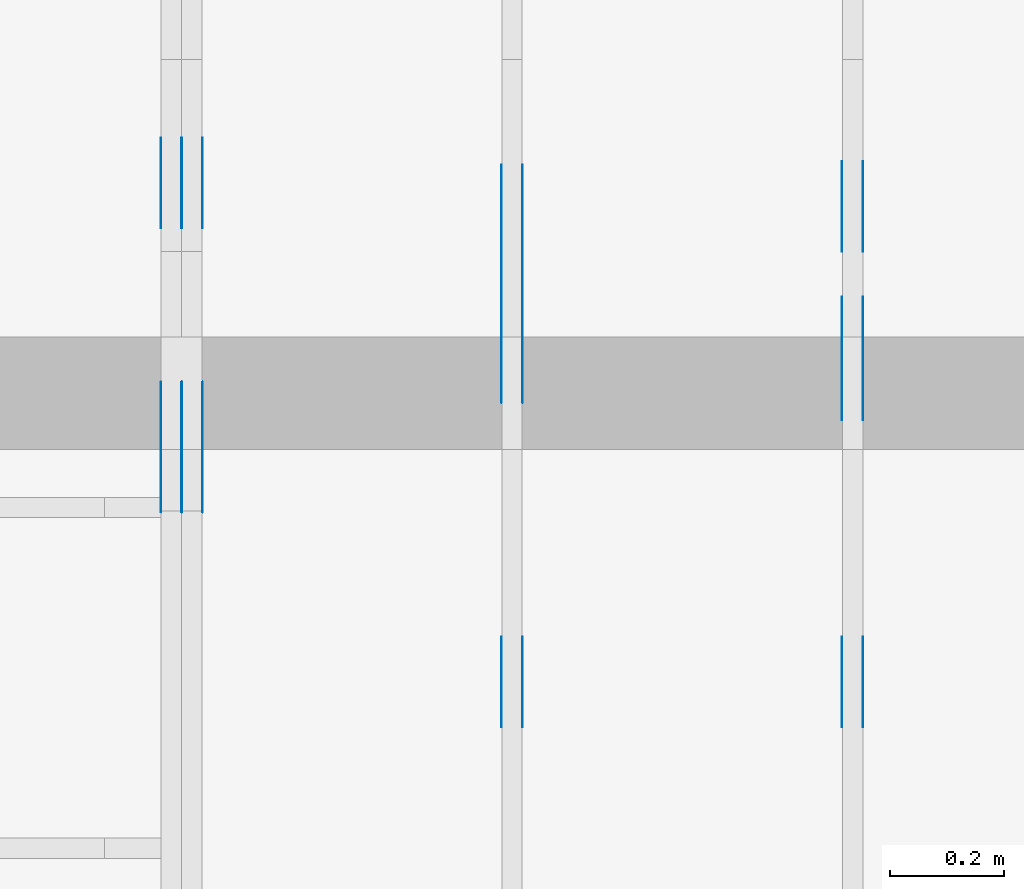
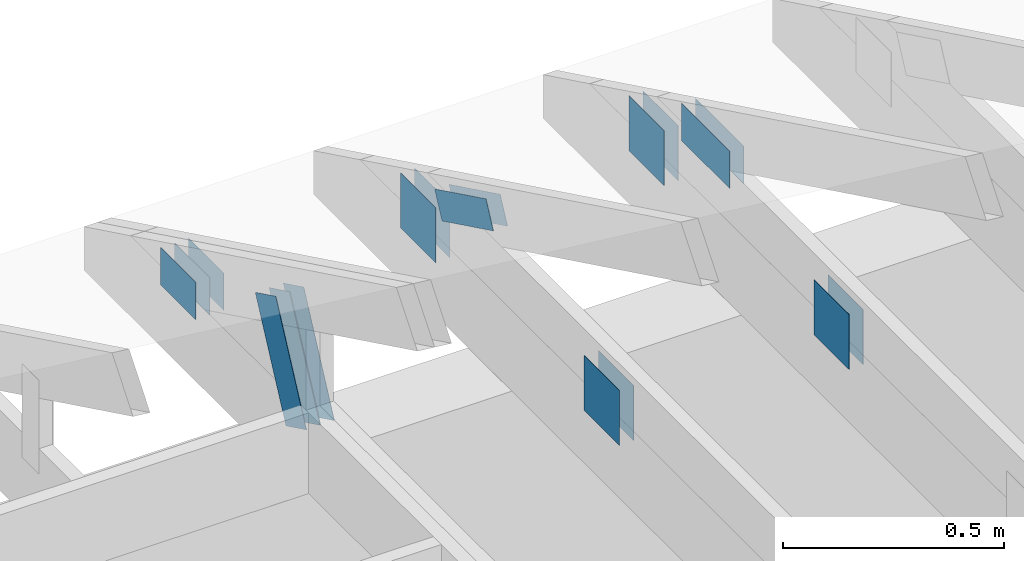
# One storey, part 91 of 159: 20 plates, 3 elements without a shape of their own.
"""IFC2X3 building model written with IfcOpenShell, lengths in millimetres."""

from ifc_helpers import new_model, si_unit, frame, origin, origin_with_axes, origin_2d, place, context, project, spatial, faceted_brep, element, aggregate, save


model = new_model("IFC2X3")

# Units and contexts
model_context = context("Model", 3, precision=1e-05, world=origin())
plan_context = context("Plan", 2, precision=1e-05, world=origin_2d())
ifc_project = project(units=[si_unit("LENGTHUNIT", "METRE", prefix="MILLI"), si_unit("AREAUNIT", "SQUARE_METRE"), si_unit("VOLUMEUNIT", "CUBIC_METRE"), si_unit("SOLIDANGLEUNIT", "STERADIAN"), si_unit("PLANEANGLEUNIT", "RADIAN"), si_unit("MASSUNIT", "GRAM"), si_unit("TIMEUNIT", "SECOND"), si_unit("THERMODYNAMICTEMPERATUREUNIT", "DEGREE_CELSIUS"), si_unit("LUMINOUSINTENSITYUNIT", "LUMEN")], contexts=[model_context, plan_context])

# Site, building, storey
site_placement = place(None, origin_with_axes())
site = spatial("IfcSite", under=ifc_project, at=site_placement, CompositionType="ELEMENT")
building_placement = place(site_placement, origin_with_axes())
building = spatial("IfcBuilding", under=site, at=building_placement, Name="Plan 1", CompositionType="ELEMENT")
storey_placement = place(building_placement, origin_with_axes())
storey = spatial("IfcBuildingStorey", under=building, at=storey_placement, Name="Etasje 1", CompositionType="ELEMENT", Elevation=0.0)

# Assembly, plates
assembly_1_placement = place(storey_placement, frame((3075.02226140475, 9699.999999999993, 1.1021457184401395e-15), z_axis=(-1.0, 1.836909530733566e-16, 6.123031769111886e-17), x_axis=(-1.836909530733566e-16, -1.0, 0.0)))
assembly_1 = element("IfcElementAssembly", 1, at=assembly_1_placement, inside=storey, Name="V3 (4)", AssemblyPlace="FACTORY", PredefinedType="TRUSS")
plate_1_placement = place(assembly_1_placement, frame((628.6262642368674, 319.5, 0.0), z_axis=(0.0, 0.0, 1.0), x_axis=(1.0, 0.0, 0.0)))
plate_1 = element("IfcPlate", 2, at=plate_1_placement, Name="GNT100S 103x218", context=model_context, shape_type="Brep", body=[
    faceted_brep([(218.00001750141382, 103.0, 1.0), (1.7501413822174072e-05, 103.0, 1.0), (1.7501413822174072e-05, 0.0, 1.0), (218.00001750141382, 0.0, 1.0), (1.7501413822174072e-05, 103.0, 2.1432342567509146e-21), (218.00001750141382, 103.0, 2.669642065656208e-14), (218.00001750141382, 0.0, 2.669642065656208e-14), (1.7501413822174072e-05, 0.0, 2.1432342567509146e-21), (218.0, 9.262934928637445e-13, 2.4519452801791947e-30), (218.0, 9.263547231814356e-13, 1.0), (1.1247455413666031e-32, 9.663993509514274e-13, 1.0), (0.0, 9.663381206337363e-13, 0.0), (218.0, 103.00000000000097, 0.0), (218.0, 103.00000000000097, 1.0), (218.0, 9.663381206337363e-13, 1.0), (218.0, 9.663381206337363e-13, 0.0), (0.0, 103.00000000000097, 0.0), (-3.7491518045553436e-33, 103.00000000000097, 1.0), (218.0, 103.00000000000095, 1.0), (218.0, 103.00000000000095, -7.888609052210118e-31), (1.1833838024688483e-28, 9.663381206337363e-13, -7.245896617569183e-45), (6.12303176912372e-17, 9.663381206337363e-13, 1.0), (1.2674675762061723e-14, 103.00000000000097, 1.0), (1.2613445444370604e-14, 103.00000000000097, -7.7232527173840805e-31)], [[[0, 1, 2, 3]], [[4, 5, 6, 7]], [[8, 9, 10, 11]], [[12, 13, 14, 15]], [[16, 17, 18, 19]], [[20, 21, 22, 23]]]),
])
plate_2_placement = place(assembly_1_placement, frame((628.6262642368674, 319.5, -37.0), z_axis=(0.0, 0.0, 1.0), x_axis=(1.0, 0.0, 0.0)))
plate_2 = element("IfcPlate", 3, at=plate_2_placement, Name="GNT100S 103x218", context=model_context, shape_type="Brep", body=[
    faceted_brep([(218.00001750141382, 103.0, 1.0), (1.7501413822174072e-05, 103.0, 1.0), (1.7501413822174072e-05, 0.0, 1.0), (218.00001750141382, 0.0, 1.0), (1.7501413822174072e-05, 103.0, 2.1432342567509146e-21), (218.00001750141382, 103.0, 2.669642065656208e-14), (218.00001750141382, 0.0, 2.669642065656208e-14), (1.7501413822174072e-05, 0.0, 2.1432342567509146e-21), (218.0, 9.262934928637445e-13, 2.4519452801791947e-30), (218.0, 9.263547231814356e-13, 1.0), (1.1247455413666031e-32, 9.663993509514274e-13, 1.0), (0.0, 9.663381206337363e-13, 0.0), (218.0, 103.00000000000097, 0.0), (218.0, 103.00000000000097, 1.0), (218.0, 9.663381206337363e-13, 1.0), (218.0, 9.663381206337363e-13, 0.0), (0.0, 103.00000000000097, 0.0), (-3.7491518045553436e-33, 103.00000000000097, 1.0), (218.0, 103.00000000000095, 1.0), (218.0, 103.00000000000095, -7.888609052210118e-31), (1.1833838024688483e-28, 9.663381206337363e-13, -7.245896617569183e-45), (6.12303176912372e-17, 9.663381206337363e-13, 1.0), (1.2674675762061723e-14, 103.00000000000097, 1.0), (1.2613445444370604e-14, 103.00000000000097, -7.7232527173840805e-31)], [[[0, 1, 2, 3]], [[4, 5, 6, 7]], [[8, 9, 10, 11]], [[12, 13, 14, 15]], [[16, 17, 18, 19]], [[20, 21, 22, 23]]]),
])
plate_3_placement = place(assembly_1_placement, frame((1227.851282296476, 147.0, 0.0), z_axis=(0.0, 0.0, 1.0), x_axis=(1.0, 0.0, 0.0)))
plate_3 = element("IfcPlate", 4, at=plate_3_placement, Name="GNT100S 152x159", context=model_context, shape_type="Brep", body=[
    faceted_brep([(159.00003606289897, 152.0, 1.0), (3.6062898971067625e-05, 152.0, 1.0), (3.6062898971067625e-05, 0.0, 1.0), (159.00003606289897, 0.0, 1.0), (3.6062898971067625e-05, 152.0, 4.4162855217223885e-21), (159.00003606289897, 152.0, 1.947124544206132e-14), (159.00003606289897, 0.0, 1.947124544206132e-14), (3.6062898971067625e-05, 0.0, 4.4162855217223885e-21), (159.0, 8.447997618295233e-14, 1.788345410772899e-30), (159.0, 8.454120650064345e-14, 1.0), (1.1247455413666031e-32, 1.1374806803930715e-13, 1.0), (0.0, 1.1368683772161603e-13, 0.0), (159.0, 152.0000000000001, 0.0), (159.0, 152.0000000000001, 1.0), (159.0, 1.1368683772161603e-13, 1.0), (159.0, 1.1368683772161603e-13, 0.0), (4.861730685829017e-63, 152.0000000000001, 0.0), (-3.7491518045553436e-33, 152.0000000000001, 1.0), (159.0, 152.0000000000001, 1.0), (159.0, 152.0000000000001, 0.0), (1.392216238198645e-29, 1.1368683772161603e-13, -8.524584255963745e-46), (6.123031769113279e-17, 1.1368683772161603e-13, 1.0), (1.8675246895791266e-14, 152.0000000000001, 1.0), (1.8614016578100147e-14, 152.0000000000001, -1.1397421485848253e-30)], [[[0, 1, 2, 3]], [[4, 5, 6, 7]], [[8, 9, 10, 11]], [[12, 13, 14, 15]], [[16, 17, 18, 19]], [[20, 21, 22, 23]]]),
])
plate_4_placement = place(assembly_1_placement, frame((1227.851282296476, 147.0, -37.0), z_axis=(0.0, 0.0, 1.0), x_axis=(1.0, 0.0, 0.0)))
plate_4 = element("IfcPlate", 5, at=plate_4_placement, Name="GNT100S 152x159", context=model_context, shape_type="Brep", body=[
    faceted_brep([(159.00003606289897, 152.0, 1.0), (3.6062898971067625e-05, 152.0, 1.0), (3.6062898971067625e-05, 0.0, 1.0), (159.00003606289897, 0.0, 1.0), (3.6062898971067625e-05, 152.0, 4.4162855217223885e-21), (159.00003606289897, 152.0, 1.947124544206132e-14), (159.00003606289897, 0.0, 1.947124544206132e-14), (3.6062898971067625e-05, 0.0, 4.4162855217223885e-21), (159.0, 8.447997618295233e-14, 1.788345410772899e-30), (159.0, 8.454120650064345e-14, 1.0), (1.1247455413666031e-32, 1.1374806803930715e-13, 1.0), (0.0, 1.1368683772161603e-13, 0.0), (159.0, 152.0000000000001, 0.0), (159.0, 152.0000000000001, 1.0), (159.0, 1.1368683772161603e-13, 1.0), (159.0, 1.1368683772161603e-13, 0.0), (4.861730685829017e-63, 152.0000000000001, 0.0), (-3.7491518045553436e-33, 152.0000000000001, 1.0), (159.0, 152.0000000000001, 1.0), (159.0, 152.0000000000001, 0.0), (1.392216238198645e-29, 1.1368683772161603e-13, -8.524584255963745e-46), (6.123031769113279e-17, 1.1368683772161603e-13, 1.0), (1.8675246895791266e-14, 152.0000000000001, 1.0), (1.8614016578100147e-14, 152.0000000000001, -1.1397421485848253e-30)], [[[0, 1, 2, 3]], [[4, 5, 6, 7]], [[8, 9, 10, 11]], [[12, 13, 14, 15]], [[16, 17, 18, 19]], [[20, 21, 22, 23]]]),
])
plate_5_placement = place(assembly_1_placement, frame((390.2917064386552, 147.0, 0.0), z_axis=(0.0, 0.0, 1.0), x_axis=(1.0, 0.0, 0.0)))
plate_5 = element("IfcPlate", 6, at=plate_5_placement, Name="GNT100S 152x159", context=model_context, shape_type="Brep", body=[
    faceted_brep([(158.99998057306357, 152.0, 1.0), (1.109064169213525e-05, 152.0, 1.0), (1.109064169213525e-05, 0.0, 1.0), (158.99998057306357, 0.0, 1.0), (1.109064169213525e-05, 152.0, 1.3581670284156189e-21), (158.99998057306357, 152.0, 1.947123864674082e-14), (158.99998057306357, 0.0, 1.947123864674082e-14), (1.109064169213525e-05, 0.0, 1.3581670284156189e-21), (159.0, 1.9816681390456836e-13, 1.788345410772899e-30), (159.0, 1.9822804422225948e-13, 1.0), (1.1247455413666031e-32, 2.274349057609232e-13, 1.0), (0.0, 2.2737367544323206e-13, 0.0), (159.0, 152.00000000000023, 0.0), (159.0, 152.00000000000023, 1.0), (159.0, 2.2737367544323206e-13, 1.0), (159.0, 2.2737367544323206e-13, 0.0), (0.0, 152.00000000000023, 0.0), (-3.7491518045553436e-33, 152.00000000000023, 1.0), (159.0, 152.00000000000023, 1.0), (159.0, 152.00000000000023, 0.0), (2.78443247639729e-29, 2.2737367544323206e-13, -1.704916851192749e-45), (6.123031769114671e-17, 2.2737367544323206e-13, 1.0), (1.8675246895791282e-14, 152.00000000000023, 1.0), (1.8614016578100163e-14, 152.00000000000023, -1.1397421485848262e-30)], [[[0, 1, 2, 3]], [[4, 5, 6, 7]], [[8, 9, 10, 11]], [[12, 13, 14, 15]], [[16, 17, 18, 19]], [[20, 21, 22, 23]]]),
])
plate_6_placement = place(assembly_1_placement, frame((390.2917064386552, 147.0, -37.0), z_axis=(0.0, 0.0, 1.0), x_axis=(1.0, 0.0, 0.0)))
plate_6 = element("IfcPlate", 7, at=plate_6_placement, Name="GNT100S 152x159", context=model_context, shape_type="Brep", body=[
    faceted_brep([(158.99998057306357, 152.0, 1.0), (1.109064169213525e-05, 152.0, 1.0), (1.109064169213525e-05, 0.0, 1.0), (158.99998057306357, 0.0, 1.0), (1.109064169213525e-05, 152.0, 1.3581670284156189e-21), (158.99998057306357, 152.0, 1.947123864674082e-14), (158.99998057306357, 0.0, 1.947123864674082e-14), (1.109064169213525e-05, 0.0, 1.3581670284156189e-21), (159.0, 1.9816681390456836e-13, 1.788345410772899e-30), (159.0, 1.9822804422225948e-13, 1.0), (1.1247455413666031e-32, 2.274349057609232e-13, 1.0), (0.0, 2.2737367544323206e-13, 0.0), (159.0, 152.00000000000023, 0.0), (159.0, 152.00000000000023, 1.0), (159.0, 2.2737367544323206e-13, 1.0), (159.0, 2.2737367544323206e-13, 0.0), (0.0, 152.00000000000023, 0.0), (-3.7491518045553436e-33, 152.00000000000023, 1.0), (159.0, 152.00000000000023, 1.0), (159.0, 152.00000000000023, 0.0), (2.78443247639729e-29, 2.2737367544323206e-13, -1.704916851192749e-45), (6.123031769114671e-17, 2.2737367544323206e-13, 1.0), (1.8675246895791282e-14, 152.00000000000023, 1.0), (1.8614016578100163e-14, 152.00000000000023, -1.1397421485848262e-30)], [[[0, 1, 2, 3]], [[4, 5, 6, 7]], [[8, 9, 10, 11]], [[12, 13, 14, 15]], [[16, 17, 18, 19]], [[20, 21, 22, 23]]]),
])
aggregate(assembly_1, [plate_1, plate_2, plate_3, plate_4, plate_5, plate_6])

assembly_2_placement = place(storey_placement, frame((2475.02226140475, 9699.999999999993, 1.1021457184401395e-15), z_axis=(-1.0, 1.836909530733566e-16, 6.123031769111886e-17), x_axis=(-1.836909530733566e-16, -1.0, 0.0)))
assembly_2 = element("IfcElementAssembly", 8, at=assembly_2_placement, inside=storey, Name="V2 (3)", AssemblyPlace="FACTORY", PredefinedType="TRUSS")
plate_7_placement = place(assembly_2_placement, frame((584.1466632894787, 280.29593737468866, 0.0), z_axis=(0.0, 0.0, 1.0), x_axis=(0.898794046299167, 0.4383711467890774, 0.0)))
plate_7 = element("IfcPlate", 9, at=plate_7_placement, Name="GNT100S 76x258", context=model_context, shape_type="Brep", body=[
    faceted_brep([(257.9999812347945, 76.00002691228983, 1.0), (0.0, 76.00002691228983, 1.0), (1.3453948326969112e-05, 1.8024312566922163e-05, 1.0), (257.99999468874285, 1.8024312566922163e-05, 1.0), (0.0, 76.00002691228983, 0.0), (257.9999812347945, 76.00002691228983, 3.159484163061835e-14), (257.99999468874285, 0.0, 3.159484327819741e-14), (1.3453948326969112e-05, 0.0, 1.6475790605204317e-21), (258.0000074628399, 8.521038589962382e-06, 2.9018435981122237e-30), (258.0000074628399, 8.521038590023613e-06, 1.0), (7.462839903382701e-06, 8.521038637415878e-06, 1.0), (7.462839903382701e-06, 8.521038637354648e-06, 9.4039548065783e-38), (258.0000074628399, 76.00000852103864, 0.0), (258.0000074628399, 76.00000852103864, 1.0), (258.0000074628399, 8.52103863735465e-06, 1.0), (258.0000074628399, 8.52103863735465e-06, 0.0), (7.462839903382702e-06, 76.00000852103861, 0.0), (7.462839903382702e-06, 76.00000852103861, 1.0), (258.0000074628399, 76.00000852103865, 1.0), (258.0000074628399, 76.00000852103865, 7.888609052210118e-31), (7.462839903382702e-06, 8.52103863735465e-06, -9.4039548065783e-38), (7.462839903443932e-06, 8.52103863735465e-06, 1.0), (7.46283991275094e-06, 76.00000852103861, 1.0), (7.46283991268971e-06, 76.00000852103861, -5.69871103679771e-31)], [[[0, 1, 2, 3]], [[4, 5, 6, 7]], [[8, 9, 10, 11]], [[12, 13, 14, 15]], [[16, 17, 18, 19]], [[20, 21, 22, 23]]]),
])
plate_8_placement = place(assembly_2_placement, frame((584.1466632894787, 280.29593737468866, -37.00000000000001), z_axis=(0.0, 0.0, 1.0), x_axis=(0.898794046299167, 0.4383711467890774, 0.0)))
plate_8 = element("IfcPlate", 10, at=plate_8_placement, Name="GNT100S 76x258", context=model_context, shape_type="Brep", body=[
    faceted_brep([(257.9999812347945, 76.00002691228983, 1.0), (0.0, 76.00002691228983, 1.0), (1.3453948326969112e-05, 1.8024312566922163e-05, 1.0), (257.99999468874285, 1.8024312566922163e-05, 1.0), (0.0, 76.00002691228983, 0.0), (257.9999812347945, 76.00002691228983, 3.159484163061835e-14), (257.99999468874285, 0.0, 3.159484327819741e-14), (1.3453948326969112e-05, 0.0, 1.6475790605204317e-21), (258.0000074628399, 8.521038589962382e-06, 2.9018435981122237e-30), (258.0000074628399, 8.521038590023613e-06, 1.0), (7.462839903382701e-06, 8.521038637415878e-06, 1.0), (7.462839903382701e-06, 8.521038637354648e-06, 9.4039548065783e-38), (258.0000074628399, 76.00000852103864, 0.0), (258.0000074628399, 76.00000852103864, 1.0), (258.0000074628399, 8.52103863735465e-06, 1.0), (258.0000074628399, 8.52103863735465e-06, 0.0), (7.462839903382702e-06, 76.00000852103861, 0.0), (7.462839903382702e-06, 76.00000852103861, 1.0), (258.0000074628399, 76.00000852103865, 1.0), (258.0000074628399, 76.00000852103865, 7.888609052210118e-31), (7.462839903382702e-06, 8.52103863735465e-06, -9.4039548065783e-38), (7.462839903443932e-06, 8.52103863735465e-06, 1.0), (7.46283991275094e-06, 76.00000852103861, 1.0), (7.46283991268971e-06, 76.00000852103861, -5.69871103679771e-31)], [[[0, 1, 2, 3]], [[4, 5, 6, 7]], [[8, 9, 10, 11]], [[12, 13, 14, 15]], [[16, 17, 18, 19]], [[20, 21, 22, 23]]]),
])
plate_9_placement = place(assembly_2_placement, frame((1227.851282296476, 147.0, 0.0), z_axis=(0.0, 0.0, 1.0), x_axis=(1.0, 0.0, 0.0)))
plate_9 = element("IfcPlate", 11, at=plate_9_placement, Name="GNT100S 152x159", context=model_context, shape_type="Brep", body=[
    faceted_brep([(159.00003606289897, 152.0, 1.0), (3.6062898971067625e-05, 152.0, 1.0), (3.6062898971067625e-05, 0.0, 1.0), (159.00003606289897, 0.0, 1.0), (3.6062898971067625e-05, 152.0, 4.4162855217223885e-21), (159.00003606289897, 152.0, 1.947124544206132e-14), (159.00003606289897, 0.0, 1.947124544206132e-14), (3.6062898971067625e-05, 0.0, 4.4162855217223885e-21), (159.0, 8.447997618295233e-14, 1.788345410772899e-30), (159.0, 8.454120650064345e-14, 1.0), (1.1247455413666031e-32, 1.1374806803930715e-13, 1.0), (0.0, 1.1368683772161603e-13, 0.0), (159.0, 152.0000000000001, 0.0), (159.0, 152.0000000000001, 1.0), (159.0, 1.1368683772161603e-13, 1.0), (159.0, 1.1368683772161603e-13, 0.0), (4.861730685829017e-63, 152.0000000000001, 0.0), (-3.7491518045553436e-33, 152.0000000000001, 1.0), (159.0, 152.0000000000001, 1.0), (159.0, 152.0000000000001, 0.0), (1.392216238198645e-29, 1.1368683772161603e-13, -8.524584255963745e-46), (6.123031769113279e-17, 1.1368683772161603e-13, 1.0), (1.8675246895791266e-14, 152.0000000000001, 1.0), (1.8614016578100147e-14, 152.0000000000001, -1.1397421485848253e-30)], [[[0, 1, 2, 3]], [[4, 5, 6, 7]], [[8, 9, 10, 11]], [[12, 13, 14, 15]], [[16, 17, 18, 19]], [[20, 21, 22, 23]]]),
])
plate_10_placement = place(assembly_2_placement, frame((1227.851282296476, 147.0, -37.0), z_axis=(0.0, 0.0, 1.0), x_axis=(1.0, 0.0, 0.0)))
plate_10 = element("IfcPlate", 12, at=plate_10_placement, Name="GNT100S 152x159", context=model_context, shape_type="Brep", body=[
    faceted_brep([(159.00003606289897, 152.0, 1.0), (3.6062898971067625e-05, 152.0, 1.0), (3.6062898971067625e-05, 0.0, 1.0), (159.00003606289897, 0.0, 1.0), (3.6062898971067625e-05, 152.0, 4.4162855217223885e-21), (159.00003606289897, 152.0, 1.947124544206132e-14), (159.00003606289897, 0.0, 1.947124544206132e-14), (3.6062898971067625e-05, 0.0, 4.4162855217223885e-21), (159.0, 8.447997618295233e-14, 1.788345410772899e-30), (159.0, 8.454120650064345e-14, 1.0), (1.1247455413666031e-32, 1.1374806803930715e-13, 1.0), (0.0, 1.1368683772161603e-13, 0.0), (159.0, 152.0000000000001, 0.0), (159.0, 152.0000000000001, 1.0), (159.0, 1.1368683772161603e-13, 1.0), (159.0, 1.1368683772161603e-13, 0.0), (4.861730685829017e-63, 152.0000000000001, 0.0), (-3.7491518045553436e-33, 152.0000000000001, 1.0), (159.0, 152.0000000000001, 1.0), (159.0, 152.0000000000001, 0.0), (1.392216238198645e-29, 1.1368683772161603e-13, -8.524584255963745e-46), (6.123031769113279e-17, 1.1368683772161603e-13, 1.0), (1.8675246895791266e-14, 152.0000000000001, 1.0), (1.8614016578100147e-14, 152.0000000000001, -1.1397421485848253e-30)], [[[0, 1, 2, 3]], [[4, 5, 6, 7]], [[8, 9, 10, 11]], [[12, 13, 14, 15]], [[16, 17, 18, 19]], [[20, 21, 22, 23]]]),
])
plate_11_placement = place(assembly_2_placement, frame((396.2348521906083, 147.0, 0.0), z_axis=(0.0, 0.0, 1.0), x_axis=(1.0, 0.0, 0.0)))
plate_11 = element("IfcPlate", 13, at=plate_11_placement, Name="GNT100S 152x159", context=model_context, shape_type="Brep", body=[
    faceted_brep([(159.0000110906417, 152.0, 1.0), (1.109064169213525e-05, 152.0, 1.0), (1.109064169213525e-05, 0.0, 1.0), (159.0000110906417, 0.0, 1.0), (1.109064169213525e-05, 152.0, 1.3581670284156189e-21), (159.0000110906417, 152.0, 1.9471242383942826e-14), (159.0000110906417, 0.0, 1.9471242383942826e-14), (1.109064169213525e-05, 0.0, 1.3581670284156189e-21), (159.0, 1.9816681390456836e-13, 1.788345410772899e-30), (159.0, 1.9822804422225948e-13, 1.0), (1.1247455413666031e-32, 2.274349057609232e-13, 1.0), (0.0, 2.2737367544323206e-13, 0.0), (159.0, 152.00000000000023, 0.0), (159.0, 152.00000000000023, 1.0), (159.0, 2.2737367544323206e-13, 1.0), (159.0, 2.2737367544323206e-13, 0.0), (0.0, 152.00000000000023, 0.0), (-3.7491518045553436e-33, 152.00000000000023, 1.0), (159.0, 152.00000000000023, 1.0), (159.0, 152.00000000000023, 0.0), (2.78443247639729e-29, 2.2737367544323206e-13, -1.704916851192749e-45), (6.123031769114671e-17, 2.2737367544323206e-13, 1.0), (1.8675246895791282e-14, 152.00000000000023, 1.0), (1.8614016578100163e-14, 152.00000000000023, -1.1397421485848262e-30)], [[[0, 1, 2, 3]], [[4, 5, 6, 7]], [[8, 9, 10, 11]], [[12, 13, 14, 15]], [[16, 17, 18, 19]], [[20, 21, 22, 23]]]),
])
plate_12_placement = place(assembly_2_placement, frame((396.2348521906083, 147.0, -37.0), z_axis=(0.0, 0.0, 1.0), x_axis=(1.0, 0.0, 0.0)))
plate_12 = element("IfcPlate", 14, at=plate_12_placement, Name="GNT100S 152x159", context=model_context, shape_type="Brep", body=[
    faceted_brep([(159.0000110906417, 152.0, 1.0), (1.109064169213525e-05, 152.0, 1.0), (1.109064169213525e-05, 0.0, 1.0), (159.0000110906417, 0.0, 1.0), (1.109064169213525e-05, 152.0, 1.3581670284156189e-21), (159.0000110906417, 152.0, 1.9471242383942826e-14), (159.0000110906417, 0.0, 1.9471242383942826e-14), (1.109064169213525e-05, 0.0, 1.3581670284156189e-21), (159.0, 1.9816681390456836e-13, 1.788345410772899e-30), (159.0, 1.9822804422225948e-13, 1.0), (1.1247455413666031e-32, 2.274349057609232e-13, 1.0), (0.0, 2.2737367544323206e-13, 0.0), (159.0, 152.00000000000023, 0.0), (159.0, 152.00000000000023, 1.0), (159.0, 2.2737367544323206e-13, 1.0), (159.0, 2.2737367544323206e-13, 0.0), (0.0, 152.00000000000023, 0.0), (-3.7491518045553436e-33, 152.00000000000023, 1.0), (159.0, 152.00000000000023, 1.0), (159.0, 152.00000000000023, 0.0), (2.78443247639729e-29, 2.2737367544323206e-13, -1.704916851192749e-45), (6.123031769114671e-17, 2.2737367544323206e-13, 1.0), (1.8675246895791282e-14, 152.00000000000023, 1.0), (1.8614016578100163e-14, 152.00000000000023, -1.1397421485848262e-30)], [[[0, 1, 2, 3]], [[4, 5, 6, 7]], [[8, 9, 10, 11]], [[12, 13, 14, 15]], [[16, 17, 18, 19]], [[20, 21, 22, 23]]]),
])
aggregate(assembly_2, [plate_7, plate_8, plate_9, plate_10, plate_11, plate_12])

assembly_3_placement = place(storey_placement, frame((1875.0222614047502, 9699.999999999993, 0.0), z_axis=(-1.0, 1.836909530733566e-16, 6.123031769111886e-17), x_axis=(-1.836909530733566e-16, -1.0, 0.0)))
assembly_3 = element("IfcElementAssembly", 15, at=assembly_3_placement, inside=storey, Name="V1 (2)", AssemblyPlace="FACTORY", PredefinedType="TRUSS")
plate_13_placement = place(assembly_3_placement, frame((348.93719482421875, 171.5, 0.0), z_axis=(0.0, 0.0, 1.0), x_axis=(1.0, 0.0, 0.0)))
plate_13 = element("IfcPlate", 16, at=plate_13_placement, Name="GNT100S 103x159", context=model_context, shape_type="Brep", body=[
    faceted_brep([(159.0, 103.0, 1.0), (0.0, 103.0, 1.0), (0.0, 0.0, 1.0), (159.0, 0.0, 1.0), (0.0, 103.0, 0.0), (159.0, 103.0, 1.9471241025775798e-14), (159.0, 0.0, 1.9471241025775798e-14), (0.0, 0.0, 0.0), (159.00001516602936, 1.1360832223220383e-12, 1.7883455813521426e-30), (159.00001516602936, 1.1361444526397294e-12, 1.0), (1.5166029356805666e-05, 1.1653513141783931e-12, 1.0), (1.5166029356805666e-05, 1.165290083860702e-12, 1.7057924370395682e-37), (159.00001516602936, 103.00000000000114, 0.0), (159.00001516602936, 103.00000000000114, 1.0), (159.00001516602936, 1.1652900866465643e-12, 1.0), (159.00001516602936, 1.1652900866465643e-12, 0.0), (1.5166029356805666e-05, 103.00000000000114, 0.0), (1.5166029356805666e-05, 103.00000000000114, 1.0), (159.00001516602936, 103.00000000000112, 1.0), (159.00001516602936, 103.00000000000112, -7.888609052210118e-31), (1.5166029356805666e-05, 1.1652900866465643e-12, 0.0), (1.5166029356866896e-05, 1.1652900866465643e-12, 1.0), (1.5166029369480342e-05, 103.00000000000114, 1.0), (1.5166029369419111e-05, 103.00000000000114, -7.7232517916822065e-31)], [[[0, 1, 2, 3]], [[4, 5, 6, 7]], [[8, 9, 10, 11]], [[12, 13, 14, 15]], [[16, 17, 18, 19]], [[20, 21, 22, 23]]]),
])
plate_14_placement = place(assembly_3_placement, frame((348.93719482421875, 171.5, -37.0), z_axis=(0.0, 0.0, 1.0), x_axis=(1.0, 0.0, 0.0)))
plate_14 = element("IfcPlate", 17, at=plate_14_placement, Name="GNT100S 103x159", context=model_context, shape_type="Brep", body=[
    faceted_brep([(159.0, 103.0, 1.0), (0.0, 103.0, 1.0), (0.0, 0.0, 1.0), (159.0, 0.0, 1.0), (0.0, 103.0, 0.0), (159.0, 103.0, 1.9471241025775798e-14), (159.0, 0.0, 1.9471241025775798e-14), (0.0, 0.0, 0.0), (159.00001516602936, 1.1360832223220383e-12, 1.7883455813521426e-30), (159.00001516602936, 1.1361444526397294e-12, 1.0), (1.5166029356805666e-05, 1.1653513141783931e-12, 1.0), (1.5166029356805666e-05, 1.165290083860702e-12, 1.7057924370395682e-37), (159.00001516602936, 103.00000000000114, 0.0), (159.00001516602936, 103.00000000000114, 1.0), (159.00001516602936, 1.1652900866465643e-12, 1.0), (159.00001516602936, 1.1652900866465643e-12, 0.0), (1.5166029356805666e-05, 103.00000000000114, 0.0), (1.5166029356805666e-05, 103.00000000000114, 1.0), (159.00001516602936, 103.00000000000112, 1.0), (159.00001516602936, 103.00000000000112, -7.888609052210118e-31), (1.5166029356805666e-05, 1.1652900866465643e-12, 0.0), (1.5166029356866896e-05, 1.1652900866465643e-12, 1.0), (1.5166029369480342e-05, 103.00000000000114, 1.0), (1.5166029369419111e-05, 103.00000000000114, -7.7232517916822065e-31)], [[[0, 1, 2, 3]], [[4, 5, 6, 7]], [[8, 9, 10, 11]], [[12, 13, 14, 15]], [[16, 17, 18, 19]], [[20, 21, 22, 23]]]),
])
plate_15_placement = place(assembly_3_placement, frame((348.93719482421875, 171.5, -36.0), z_axis=(0.0, 0.0, 1.0), x_axis=(1.0, 0.0, 0.0)))
plate_15 = element("IfcPlate", 18, at=plate_15_placement, Name="GNT100S 103x159", context=model_context, shape_type="Brep", body=[
    faceted_brep([(159.0, 103.0, 1.0), (0.0, 103.0, 1.0), (0.0, 0.0, 1.0), (159.0, 0.0, 1.0), (0.0, 103.0, 0.0), (159.0, 103.0, 1.9471241025775798e-14), (159.0, 0.0, 1.9471241025775798e-14), (0.0, 0.0, 0.0), (159.00001516602936, 1.1360832223220383e-12, 1.7883455813521426e-30), (159.00001516602936, 1.1361444526397294e-12, 1.0), (1.5166029356805666e-05, 1.1653513141783931e-12, 1.0), (1.5166029356805666e-05, 1.165290083860702e-12, 1.7057924370395682e-37), (159.00001516602936, 103.00000000000114, 0.0), (159.00001516602936, 103.00000000000114, 1.0), (159.00001516602936, 1.1652900866465643e-12, 1.0), (159.00001516602936, 1.1652900866465643e-12, 0.0), (1.5166029356805666e-05, 103.00000000000114, 0.0), (1.5166029356805666e-05, 103.00000000000114, 1.0), (159.00001516602936, 103.00000000000112, 1.0), (159.00001516602936, 103.00000000000112, -7.888609052210118e-31), (1.5166029356805666e-05, 1.1652900866465643e-12, 0.0), (1.5166029356866896e-05, 1.1652900866465643e-12, 1.0), (1.5166029369480342e-05, 103.00000000000114, 1.0), (1.5166029369419111e-05, 103.00000000000114, -7.7232517916822065e-31)], [[[0, 1, 2, 3]], [[4, 5, 6, 7]], [[8, 9, 10, 11]], [[12, 13, 14, 15]], [[16, 17, 18, 19]], [[20, 21, 22, 23]]]),
])
plate_16_placement = place(assembly_3_placement, frame((348.93719482421875, 171.5, -73.0), z_axis=(0.0, 0.0, 1.0), x_axis=(1.0, 0.0, 0.0)))
plate_16 = element("IfcPlate", 19, at=plate_16_placement, Name="GNT100S 103x159", context=model_context, shape_type="Brep", body=[
    faceted_brep([(159.0, 103.0, 1.0), (0.0, 103.0, 1.0), (0.0, 0.0, 1.0), (159.0, 0.0, 1.0), (0.0, 103.0, 0.0), (159.0, 103.0, 1.9471241025775798e-14), (159.0, 0.0, 1.9471241025775798e-14), (0.0, 0.0, 0.0), (159.00001516602936, 1.1360832223220383e-12, 1.7883455813521426e-30), (159.00001516602936, 1.1361444526397294e-12, 1.0), (1.5166029356805666e-05, 1.1653513141783931e-12, 1.0), (1.5166029356805666e-05, 1.165290083860702e-12, 1.7057924370395682e-37), (159.00001516602936, 103.00000000000114, 0.0), (159.00001516602936, 103.00000000000114, 1.0), (159.00001516602936, 1.1652900866465643e-12, 1.0), (159.00001516602936, 1.1652900866465643e-12, 0.0), (1.5166029356805666e-05, 103.00000000000114, 0.0), (1.5166029356805666e-05, 103.00000000000114, 1.0), (159.00001516602936, 103.00000000000112, 1.0), (159.00001516602936, 103.00000000000112, -7.888609052210118e-31), (1.5166029356805666e-05, 1.1652900866465643e-12, 0.0), (1.5166029356866896e-05, 1.1652900866465643e-12, 1.0), (1.5166029369480342e-05, 103.00000000000114, 1.0), (1.5166029369419111e-05, 103.00000000000114, -7.7232517916822065e-31)], [[[0, 1, 2, 3]], [[4, 5, 6, 7]], [[8, 9, 10, 11]], [[12, 13, 14, 15]], [[16, 17, 18, 19]], [[20, 21, 22, 23]]]),
])
plate_17_placement = place(assembly_3_placement, frame((1009.2211914711825, 170.79782091179138, 0.0), z_axis=(0.0, 0.0, 1.0), x_axis=(-0.4383711467890776, 0.8987940462991671, 0.0)))
plate_17 = element("IfcPlate", 20, at=plate_17_placement, Name="GNT100S 103x317", context=model_context, shape_type="Brep", body=[
    faceted_brep([(316.99998415113396, 103.0000208490203, 1.0), (5.04607100992871e-07, 103.0000208490203, 1.0), (1.4812138715569745e-07, 0.0, 1.0), (316.9999968361908, 0.0, 1.0), (5.04607100992871e-07, 103.0000208490203, 6.179450620597598e-23), (316.99998415113396, 103.0000208490203, 3.8820019475307157e-14), (316.9999968361908, 3.5605207472144684e-05, 3.8820021028727274e-14), (1.4812138715569745e-07, 3.5605207472144684e-05, 1.8139039184785136e-23), (317.00000000000006, 1.181797898514142e-05, 3.565443355111872e-30), (317.00000000000006, 1.181797898520265e-05, 1.0), (5.684341886080802e-14, 1.1817979043432682e-05, 1.0), (5.684341886080802e-14, 1.1817979043371452e-05, 0.0), (317.00000000000006, 103.00001181797916, 3.1554436208840472e-30), (317.00000000000006, 103.00001181797916, 1.0), (317.00000000000006, 1.1817979043371452e-05, 1.0), (317.00000000000006, 1.1817979043371452e-05, 0.0), (0.0, 103.00001181797904, 0.0), (0.0, 103.00001181797904, 1.0), (317.0, 103.00001181797917, 1.0), (317.0, 103.00001181797917, 0.0), (5.684342158188916e-14, 1.1817979043371452e-05, -1.6661266240981117e-37), (5.690465189958028e-14, 1.1817979043371452e-05, 1.0), (2.3776908729394313e-14, 103.00001181797904, 1.0), (2.3715678411703194e-14, 103.00001181797904, -1.4521185234089953e-30)], [[[0, 1, 2, 3]], [[4, 5, 6, 7]], [[8, 9, 10, 11]], [[12, 13, 14, 15]], [[16, 17, 18, 19]], [[20, 21, 22, 23]]]),
])
plate_18_placement = place(assembly_3_placement, frame((1009.2211914711825, 170.79782091179138, -37.00000000000001), z_axis=(0.0, 0.0, 1.0), x_axis=(-0.4383711467890776, 0.8987940462991671, 0.0)))
plate_18 = element("IfcPlate", 21, at=plate_18_placement, Name="GNT100S 103x317", context=model_context, shape_type="Brep", body=[
    faceted_brep([(316.99998415113396, 103.0000208490203, 1.0), (5.04607100992871e-07, 103.0000208490203, 1.0), (1.4812138715569745e-07, 0.0, 1.0), (316.9999968361908, 0.0, 1.0), (5.04607100992871e-07, 103.0000208490203, 6.179450620597598e-23), (316.99998415113396, 103.0000208490203, 3.8820019475307157e-14), (316.9999968361908, 3.5605207472144684e-05, 3.8820021028727274e-14), (1.4812138715569745e-07, 3.5605207472144684e-05, 1.8139039184785136e-23), (317.00000000000006, 1.181797898514142e-05, 3.565443355111872e-30), (317.00000000000006, 1.181797898520265e-05, 1.0), (5.684341886080802e-14, 1.1817979043432682e-05, 1.0), (5.684341886080802e-14, 1.1817979043371452e-05, 0.0), (317.00000000000006, 103.00001181797916, 3.1554436208840472e-30), (317.00000000000006, 103.00001181797916, 1.0), (317.00000000000006, 1.1817979043371452e-05, 1.0), (317.00000000000006, 1.1817979043371452e-05, 0.0), (0.0, 103.00001181797904, 0.0), (0.0, 103.00001181797904, 1.0), (317.0, 103.00001181797917, 1.0), (317.0, 103.00001181797917, 0.0), (5.684342158188916e-14, 1.1817979043371452e-05, -1.6661266240981117e-37), (5.690465189958028e-14, 1.1817979043371452e-05, 1.0), (2.3776908729394313e-14, 103.00001181797904, 1.0), (2.3715678411703194e-14, 103.00001181797904, -1.4521185234089953e-30)], [[[0, 1, 2, 3]], [[4, 5, 6, 7]], [[8, 9, 10, 11]], [[12, 13, 14, 15]], [[16, 17, 18, 19]], [[20, 21, 22, 23]]]),
])
plate_19_placement = place(assembly_3_placement, frame((1009.2211914711825, 170.79782091179138, -36.00000000000001), z_axis=(0.0, 0.0, 1.0), x_axis=(-0.4383711467890776, 0.8987940462991671, 0.0)))
plate_19 = element("IfcPlate", 22, at=plate_19_placement, Name="GNT100S 103x317", context=model_context, shape_type="Brep", body=[
    faceted_brep([(316.99998415113396, 103.0000208490203, 1.0), (5.04607100992871e-07, 103.0000208490203, 1.0), (1.4812138715569745e-07, 0.0, 1.0), (316.9999968361908, 0.0, 1.0), (5.04607100992871e-07, 103.0000208490203, 6.179450620597598e-23), (316.99998415113396, 103.0000208490203, 3.8820019475307157e-14), (316.9999968361908, 3.5605207472144684e-05, 3.8820021028727274e-14), (1.4812138715569745e-07, 3.5605207472144684e-05, 1.8139039184785136e-23), (317.00000000000006, 1.181797898514142e-05, 3.565443355111872e-30), (317.00000000000006, 1.181797898520265e-05, 1.0), (5.684341886080802e-14, 1.1817979043432682e-05, 1.0), (5.684341886080802e-14, 1.1817979043371452e-05, 0.0), (317.00000000000006, 103.00001181797916, 3.1554436208840472e-30), (317.00000000000006, 103.00001181797916, 1.0), (317.00000000000006, 1.1817979043371452e-05, 1.0), (317.00000000000006, 1.1817979043371452e-05, 0.0), (0.0, 103.00001181797904, 0.0), (0.0, 103.00001181797904, 1.0), (317.0, 103.00001181797917, 1.0), (317.0, 103.00001181797917, 0.0), (5.684342158188916e-14, 1.1817979043371452e-05, -1.6661266240981117e-37), (5.690465189958028e-14, 1.1817979043371452e-05, 1.0), (2.3776908729394313e-14, 103.00001181797904, 1.0), (2.3715678411703194e-14, 103.00001181797904, -1.4521185234089953e-30)], [[[0, 1, 2, 3]], [[4, 5, 6, 7]], [[8, 9, 10, 11]], [[12, 13, 14, 15]], [[16, 17, 18, 19]], [[20, 21, 22, 23]]]),
])
plate_20_placement = place(assembly_3_placement, frame((1009.2211914711825, 170.79782091179138, -73.00000000000001), z_axis=(0.0, 0.0, 1.0), x_axis=(-0.4383711467890776, 0.8987940462991671, 0.0)))
plate_20 = element("IfcPlate", 23, at=plate_20_placement, Name="GNT100S 103x317", context=model_context, shape_type="Brep", body=[
    faceted_brep([(316.99998415113396, 103.0000208490203, 1.0), (5.04607100992871e-07, 103.0000208490203, 1.0), (1.4812138715569745e-07, 0.0, 1.0), (316.9999968361908, 0.0, 1.0), (5.04607100992871e-07, 103.0000208490203, 6.179450620597598e-23), (316.99998415113396, 103.0000208490203, 3.8820019475307157e-14), (316.9999968361908, 3.5605207472144684e-05, 3.8820021028727274e-14), (1.4812138715569745e-07, 3.5605207472144684e-05, 1.8139039184785136e-23), (317.00000000000006, 1.181797898514142e-05, 3.565443355111872e-30), (317.00000000000006, 1.181797898520265e-05, 1.0), (5.684341886080802e-14, 1.1817979043432682e-05, 1.0), (5.684341886080802e-14, 1.1817979043371452e-05, 0.0), (317.00000000000006, 103.00001181797916, 3.1554436208840472e-30), (317.00000000000006, 103.00001181797916, 1.0), (317.00000000000006, 1.1817979043371452e-05, 1.0), (317.00000000000006, 1.1817979043371452e-05, 0.0), (0.0, 103.00001181797904, 0.0), (0.0, 103.00001181797904, 1.0), (317.0, 103.00001181797917, 1.0), (317.0, 103.00001181797917, 0.0), (5.684342158188916e-14, 1.1817979043371452e-05, -1.6661266240981117e-37), (5.690465189958028e-14, 1.1817979043371452e-05, 1.0), (2.3776908729394313e-14, 103.00001181797904, 1.0), (2.3715678411703194e-14, 103.00001181797904, -1.4521185234089953e-30)], [[[0, 1, 2, 3]], [[4, 5, 6, 7]], [[8, 9, 10, 11]], [[12, 13, 14, 15]], [[16, 17, 18, 19]], [[20, 21, 22, 23]]]),
])
aggregate(assembly_3, [plate_13, plate_14, plate_15, plate_16, plate_17, plate_18, plate_19, plate_20])

save(model, "model.ifc")
